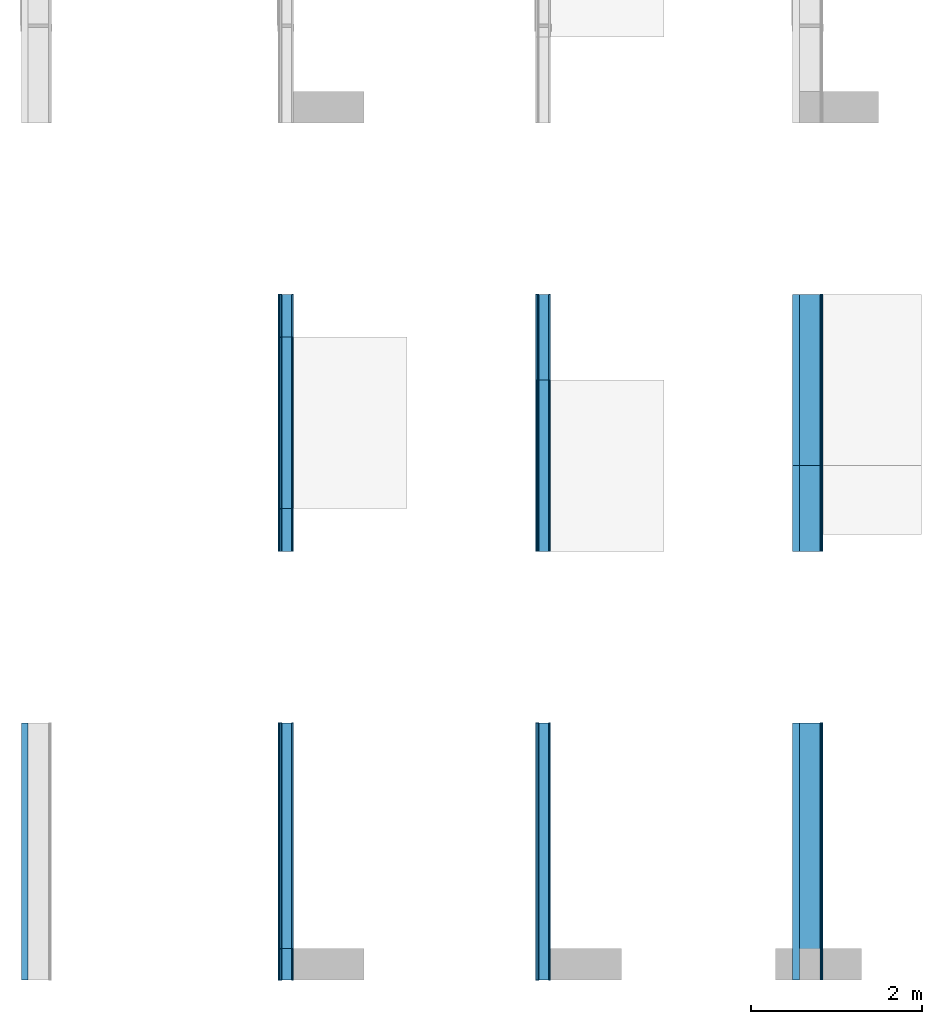
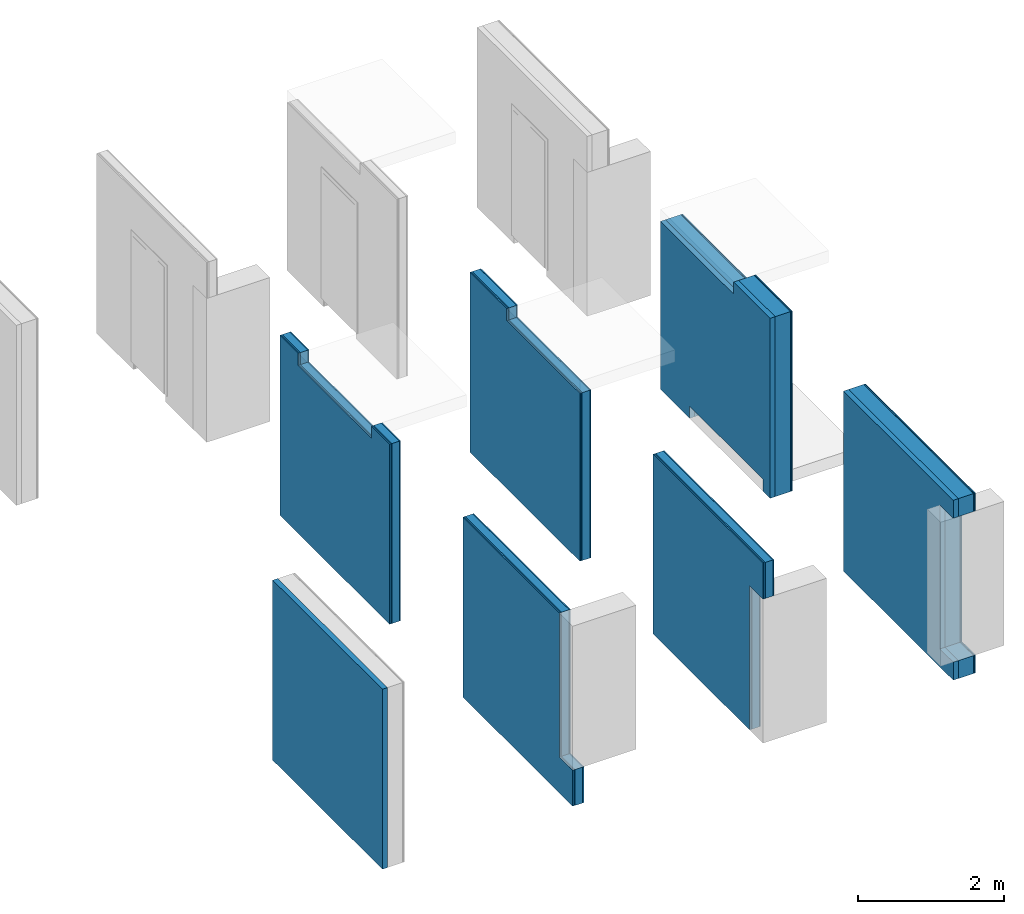
# One storey, part 2 of 2: 25 building element parts, 7 elements without a shape of their own.
"""IFC4 building model written with IfcOpenShell, lengths in metres."""

from ifc_helpers import new_model, entity, si_unit, converted_unit, derived_unit, direction, frame, origin_with_axes, place, context, subcontext, project, spatial, polygons, material, type_object, element, aggregate, save


model = new_model("IFC4")

# Units and contexts
model_context = context("Model", 3, precision=1e-05, world=origin_with_axes(), true_north=direction((0.0, 1.0)))
body_context = subcontext(model_context, "Body", "Model", "MODEL_VIEW")
ifc_project = project(units=[si_unit("LENGTHUNIT", "METRE"), si_unit("AREAUNIT", "SQUARE_METRE"), si_unit("VOLUMEUNIT", "CUBIC_METRE"), converted_unit("PLANEANGLEUNIT", "DEGREE", entity("IfcPlaneAngleMeasure", 0.0174532925199), si_unit("PLANEANGLEUNIT", "RADIAN"), dimensions=[0, 0, 0, 0, 0, 0, 0]), converted_unit("TIMEUNIT", "Year", entity("IfcTimeMeasure", 31556926.0), si_unit("TIMEUNIT", "SECOND"), dimensions=[0, 0, 1, 0, 0, 0, 0]), si_unit("MASSUNIT", "GRAM", prefix="KILO"), si_unit("THERMODYNAMICTEMPERATUREUNIT", "DEGREE_CELSIUS"), si_unit("LUMINOUSINTENSITYUNIT", "LUMEN"), si_unit("ENERGYUNIT", "JOULE", prefix="MEGA"), derived_unit("THERMALCONDUCTANCEUNIT", [(si_unit("POWERUNIT", "WATT"), 1), (si_unit("LENGTHUNIT", "METRE"), -1), (si_unit("THERMODYNAMICTEMPERATUREUNIT", "KELVIN"), -1)]), derived_unit("SPECIFICHEATCAPACITYUNIT", [(si_unit("ENERGYUNIT", "JOULE"), 1), (si_unit("MASSUNIT", "GRAM", prefix="KILO"), -1), (si_unit("THERMODYNAMICTEMPERATUREUNIT", "KELVIN"), -1)]), derived_unit("MASSDENSITYUNIT", [(si_unit("MASSUNIT", "GRAM", prefix="KILO"), 1), (si_unit("VOLUMEUNIT", "CUBIC_METRE"), -1)])], contexts=[model_context])

# Site, building, storey
site_placement = place(None, origin_with_axes())
site = spatial("IfcSite", under=ifc_project, at=site_placement, CompositionType="ELEMENT")
building_placement = place(site_placement, origin_with_axes())
building = spatial("IfcBuilding", under=site, at=building_placement, CompositionType="ELEMENT")
storey_placement = place(building_placement, origin_with_axes())
storey = spatial("IfcBuildingStorey", under=building, at=storey_placement, Name="EG", CompositionType="ELEMENT", Elevation=0.0)

# Wall, building element part
wall_type_1 = type_object("IfcWallType", PredefinedType="NOTDEFINED")
wall_1_placement = place(storey_placement, frame((0.0, 0.0, -0.15), z_axis=(0.0, 0.0, 1.0), x_axis=(0.0, -1.0, 0.0)))
wall_1 = element("IfcWall", 1, at=wall_1_placement, inside=storey, type_object=wall_type_1, Name="Wand-011", PredefinedType="NOTDEFINED")
ifc_material_1 = material(Name="Mineralwolle (1)-10")
building_element_part_1_placement = place(wall_1_placement, origin_with_axes())
building_element_part_1 = element("IfcBuildingElementPart", 2, at=building_element_part_1_placement, material=ifc_material_1, Name="Mineralwolle (1)-10", context=body_context, shape_type="Tessellation", body=[
    polygons([(3.0, 0.08, 0.0), (3.0, 0.0, 0.0), (0.0, 0.0, 0.0), (0.0, 0.08, 0.0), (3.0, 0.08, 3.0), (3.0, 0.0, 3.0), (0.0, 0.0, 3.0), (0.0, 0.08, 3.0)], [[[1, 2, 3, 4]], [[1, 5, 6, 2]], [[2, 6, 7, 3]], [[4, 3, 7, 8]], [[5, 1, 4, 8]], [[6, 5, 8, 7]]], closed=True),
])
aggregate(wall_1, [building_element_part_1])

# Wall, building element parts
wall_type_2 = type_object("IfcWallType", PredefinedType="NOTDEFINED")
wall_2_placement = place(storey_placement, frame((3.0, 0.0, -0.15), z_axis=(0.0, 0.0, 1.0), x_axis=(0.0, -1.0, 0.0)))
wall_2 = element("IfcWall", 3, at=wall_2_placement, inside=storey, type_object=wall_type_2, Name="Wand-011", PredefinedType="NOTDEFINED")
ifc_material_2 = material(Name="Gipskarton vertikal (1)-10 (2)")
building_element_part_2_placement = place(wall_2_placement, origin_with_axes())
building_element_part_2 = element("IfcBuildingElementPart", 4, at=building_element_part_2_placement, material=ifc_material_2, Name="Gipskarton vertikal (1)-10 (2)", context=body_context, shape_type="Tessellation", body=[
    polygons([(2.635, 0.156, 3.0), (2.635, 0.174, 3.0), (0.0, 0.174, 3.0), (0.0, 0.156, 3.0), (2.635, 0.174, 0.6), (2.635, 0.156, 0.6), (3.0, 0.174, 0.6), (3.0, 0.174, 0.0), (0.0, 0.174, 0.0), (0.0, 0.156, 0.0), (3.0, 0.156, 0.0), (3.0, 0.156, 0.6)], [[[1, 2, 3, 4]], [[5, 2, 1, 6]], [[5, 7, 8, 9, 3, 2]], [[4, 3, 9, 10]], [[6, 1, 4, 10, 11, 12]], [[7, 5, 6, 12]], [[7, 12, 11, 8]], [[9, 8, 11, 10]]], closed=True),
])
ifc_material_3 = material(Name="(2)-10")
building_element_part_3_placement = place(wall_2_placement, origin_with_axes())
building_element_part_3 = element("IfcBuildingElementPart", 5, at=building_element_part_3_placement, material=ifc_material_3, Name="(2)-10", context=body_context, shape_type="Tessellation", body=[
    polygons([(2.635, 0.036, 3.0), (2.635, 0.156, 3.0), (0.0, 0.156, 3.0), (0.0, 0.036, 3.0), (2.635, 0.156, 0.6), (2.635, 0.036, 0.6), (3.0, 0.156, 0.6), (3.0, 0.156, 0.0), (0.0, 0.156, 0.0), (0.0, 0.036, 0.0), (3.0, 0.036, 0.0), (3.0, 0.036, 0.6)], [[[1, 2, 3, 4]], [[5, 2, 1, 6]], [[5, 7, 8, 9, 3, 2]], [[4, 3, 9, 10]], [[6, 1, 4, 10, 11, 12]], [[7, 5, 6, 12]], [[7, 12, 11, 8]], [[9, 8, 11, 10]]], closed=True),
])
building_element_part_4_placement = place(wall_2_placement, origin_with_axes())
building_element_part_4 = element("IfcBuildingElementPart", 6, at=building_element_part_4_placement, material=ifc_material_2, Name="Gipskarton vertikal (1)-10 (2)", context=body_context, shape_type="Tessellation", body=[
    polygons([(2.635, 0.018, 3.0), (2.635, 0.036, 3.0), (0.0, 0.036, 3.0), (0.0, 0.018, 3.0), (2.635, 0.036, 0.6), (2.635, 0.018, 0.6), (3.0, 0.036, 0.6), (3.0, 0.036, 0.0), (0.0, 0.036, 0.0), (0.0, 0.018, 0.0), (3.0, 0.018, 0.0), (3.0, 0.018, 0.6)], [[[1, 2, 3, 4]], [[5, 2, 1, 6]], [[5, 7, 8, 9, 3, 2]], [[4, 3, 9, 10]], [[6, 1, 4, 10, 11, 12]], [[7, 5, 6, 12]], [[7, 12, 11, 8]], [[9, 8, 11, 10]]], closed=True),
])
building_element_part_5_placement = place(wall_2_placement, origin_with_axes())
building_element_part_5 = element("IfcBuildingElementPart", 7, at=building_element_part_5_placement, material=ifc_material_2, Name="Gipskarton vertikal (1)-10 (2)", context=body_context, shape_type="Tessellation", body=[
    polygons([(2.635, 0.0, 3.0), (2.635, 0.018, 3.0), (0.0, 0.018, 3.0), (0.0, 0.0, 3.0), (2.635, 0.018, 0.6), (2.635, 0.0, 0.6), (3.0, 0.018, 0.6), (3.0, 0.018, 0.0), (0.0, 0.018, 0.0), (0.0, 0.0, 0.0), (3.0, 0.0, 0.0), (3.0, 0.0, 0.6)], [[[1, 2, 3, 4]], [[5, 2, 1, 6]], [[5, 7, 8, 9, 3, 2]], [[4, 3, 9, 10]], [[6, 1, 4, 10, 11, 12]], [[7, 5, 6, 12]], [[7, 12, 11, 8]], [[9, 8, 11, 10]]], closed=True),
])
aggregate(wall_2, [building_element_part_2, building_element_part_3, building_element_part_4, building_element_part_5])

wall_3_placement = place(storey_placement, frame((6.0, 0.0, -0.15), z_axis=(0.0, 0.0, 1.0), x_axis=(0.0, -1.0, 0.0)))
wall_3 = element("IfcWall", 8, at=wall_3_placement, inside=storey, type_object=wall_type_2, Name="Wand-011", PredefinedType="NOTDEFINED")
building_element_part_6_placement = place(wall_3_placement, origin_with_axes())
building_element_part_6 = element("IfcBuildingElementPart", 9, at=building_element_part_6_placement, material=ifc_material_2, Name="Gipskarton vertikal (1)-10 (2)", context=body_context, shape_type="Tessellation", body=[
    polygons([(2.635, 0.174, 2.4), (2.635, 0.174, 0.0), (0.0, 0.174, 0.0), (0.0, 0.174, 3.0), (3.0, 0.174, 3.0), (3.0, 0.174, 2.4), (2.635, 0.156, 2.4), (2.635, 0.156, 0.0), (0.0, 0.156, 0.0), (0.0, 0.156, 3.0), (3.0, 0.156, 3.0), (3.0, 0.156, 2.4)], [[[1, 2, 3, 4, 5, 6]], [[2, 1, 7, 8]], [[2, 8, 9, 3]], [[10, 4, 3, 9]], [[10, 11, 5, 4]], [[12, 6, 5, 11]], [[1, 6, 12, 7]], [[7, 12, 11, 10, 9, 8]]], closed=True),
])
building_element_part_7_placement = place(wall_3_placement, origin_with_axes())
building_element_part_7 = element("IfcBuildingElementPart", 10, at=building_element_part_7_placement, material=ifc_material_3, Name="(2)-10", context=body_context, shape_type="Tessellation", body=[
    polygons([(2.635, 0.156, 2.4), (2.635, 0.156, 0.0), (0.0, 0.156, 0.0), (0.0, 0.156, 3.0), (3.0, 0.156, 3.0), (3.0, 0.156, 2.4), (2.635, 0.036, 2.4), (2.635, 0.036, 0.0), (0.0, 0.036, 0.0), (0.0, 0.036, 3.0), (3.0, 0.036, 3.0), (3.0, 0.036, 2.4)], [[[1, 2, 3, 4, 5, 6]], [[2, 1, 7, 8]], [[2, 8, 9, 3]], [[10, 4, 3, 9]], [[10, 11, 5, 4]], [[12, 6, 5, 11]], [[1, 6, 12, 7]], [[7, 12, 11, 10, 9, 8]]], closed=True),
])
building_element_part_8_placement = place(wall_3_placement, origin_with_axes())
building_element_part_8 = element("IfcBuildingElementPart", 11, at=building_element_part_8_placement, material=ifc_material_2, Name="Gipskarton vertikal (1)-10 (2)", context=body_context, shape_type="Tessellation", body=[
    polygons([(2.635, 0.036, 2.4), (2.635, 0.036, 0.0), (0.0, 0.036, 0.0), (0.0, 0.036, 3.0), (3.0, 0.036, 3.0), (3.0, 0.036, 2.4), (2.635, 0.018, 2.4), (2.635, 0.018, 0.0), (0.0, 0.018, 0.0), (0.0, 0.018, 3.0), (3.0, 0.018, 3.0), (3.0, 0.018, 2.4)], [[[1, 2, 3, 4, 5, 6]], [[2, 1, 7, 8]], [[2, 8, 9, 3]], [[10, 4, 3, 9]], [[10, 11, 5, 4]], [[12, 6, 5, 11]], [[1, 6, 12, 7]], [[7, 12, 11, 10, 9, 8]]], closed=True),
])
building_element_part_9_placement = place(wall_3_placement, origin_with_axes())
building_element_part_9 = element("IfcBuildingElementPart", 12, at=building_element_part_9_placement, material=ifc_material_2, Name="Gipskarton vertikal (1)-10 (2)", context=body_context, shape_type="Tessellation", body=[
    polygons([(2.635, 0.018, 2.4), (2.635, 0.018, 0.0), (0.0, 0.018, 0.0), (0.0, 0.018, 3.0), (3.0, 0.018, 3.0), (3.0, 0.018, 2.4), (2.635, 0.0, 2.4), (2.635, 0.0, 0.0), (0.0, 0.0, 0.0), (0.0, 0.0, 3.0), (3.0, 0.0, 3.0), (3.0, 0.0, 2.4)], [[[1, 2, 3, 4, 5, 6]], [[2, 1, 7, 8]], [[2, 8, 9, 3]], [[10, 4, 3, 9]], [[10, 11, 5, 4]], [[12, 6, 5, 11]], [[1, 6, 12, 7]], [[7, 12, 11, 10, 9, 8]]], closed=True),
])
aggregate(wall_3, [building_element_part_6, building_element_part_7, building_element_part_8, building_element_part_9])

wall_4_placement = place(storey_placement, frame((9.0, 0.0, -0.15), z_axis=(0.0, 0.0, 1.0), x_axis=(0.0, -1.0, 0.0)))
wall_4 = element("IfcWall", 13, at=wall_4_placement, inside=storey, type_object=wall_type_1, Name="Wand-011", PredefinedType="NOTDEFINED")
ifc_material_4 = material(Name="Gipskarton vertikal (1)-10")
building_element_part_10_placement = place(wall_4_placement, origin_with_axes())
building_element_part_10 = element("IfcBuildingElementPart", 14, at=building_element_part_10_placement, material=ifc_material_4, Name="Gipskarton vertikal (1)-10", context=body_context, shape_type="Tessellation", body=[
    polygons([(2.635, 0.35, 0.3), (3.0, 0.35, 0.3), (3.0, 0.35, 0.0), (0.0, 0.35, 0.0), (0.0, 0.35, 3.0), (3.0, 0.35, 3.00000000224), (3.0, 0.35, 2.7), (2.635, 0.35, 2.7), (2.635, 0.335000002235, 0.3), (3.0, 0.335000002235, 0.3), (3.0, 0.335000002235, 0.0), (0.0, 0.335, 0.0), (0.0, 0.335, 3.0), (3.0, 0.335000002235, 3.00000000224), (3.0, 0.335000002235, 2.7), (2.635, 0.335000002235, 2.7)], [[[1, 2, 3, 4, 5, 6, 7, 8]], [[2, 1, 9, 10]], [[2, 10, 11, 3]], [[4, 3, 11, 12]], [[13, 5, 4, 12]], [[13, 14, 6, 5]], [[15, 7, 6, 14]], [[8, 7, 15, 16]], [[1, 8, 16, 9]], [[16, 15, 14, 13, 12, 11, 10, 9]]], closed=True),
])
ifc_material_5 = material(Name="OSB (1)-10")
building_element_part_11_placement = place(wall_4_placement, origin_with_axes())
building_element_part_11 = element("IfcBuildingElementPart", 15, at=building_element_part_11_placement, material=ifc_material_5, Name="OSB (1)-10", context=body_context, shape_type="Tessellation", body=[
    polygons([(2.635, 0.335000002235, 0.3), (3.0, 0.335000002235, 0.3), (3.0, 0.335000002235, 0.0), (0.0, 0.335, 0.0), (0.0, 0.335, 3.0), (3.0, 0.335000002235, 3.00000000224), (3.0, 0.335000002235, 2.7), (2.635, 0.335000002235, 2.7), (2.635, 0.319999999255, 0.3), (3.0, 0.319999999255, 0.3), (3.0, 0.319999999255, 0.0), (0.0, 0.32, 0.0), (0.0, 0.32, 3.0), (3.0, 0.319999999255, 3.00000000224), (3.0, 0.319999999255, 2.7), (2.635, 0.319999999255, 2.7)], [[[1, 2, 3, 4, 5, 6, 7, 8]], [[2, 1, 9, 10]], [[2, 10, 11, 3]], [[4, 3, 11, 12]], [[13, 5, 4, 12]], [[13, 14, 6, 5]], [[15, 7, 6, 14]], [[8, 7, 15, 16]], [[1, 8, 16, 9]], [[16, 15, 14, 13, 12, 11, 10, 9]]], closed=True),
])
ifc_material_6 = material(Name="(1)-10")
building_element_part_12_placement = place(wall_4_placement, origin_with_axes())
building_element_part_12 = element("IfcBuildingElementPart", 16, at=building_element_part_12_placement, material=ifc_material_6, Name="(1)-10", context=body_context, shape_type="Tessellation", body=[
    polygons([(2.635, 0.319999999255, 0.3), (3.0, 0.319999999255, 0.3), (3.0, 0.319999999255, 0.0), (0.0, 0.32, 0.0), (0.0, 0.32, 3.0), (3.0, 0.319999999255, 3.00000000224), (3.0, 0.319999999255, 2.7), (2.635, 0.319999999255, 2.7), (2.635, 0.0799999985099, 0.3), (3.0, 0.0799999985099, 0.3), (3.0, 0.0799999985099, 0.0), (0.0, 0.08, 0.0), (0.0, 0.08, 3.0), (3.0, 0.0799999985099, 3.00000000224), (3.0, 0.0799999985099, 2.7), (2.635, 0.0799999985099, 2.7)], [[[1, 2, 3, 4, 5, 6, 7, 8]], [[2, 1, 9, 10]], [[2, 10, 11, 3]], [[4, 3, 11, 12]], [[13, 5, 4, 12]], [[13, 14, 6, 5]], [[15, 7, 6, 14]], [[8, 7, 15, 16]], [[1, 8, 16, 9]], [[16, 15, 14, 13, 12, 11, 10, 9]]], closed=True),
])
building_element_part_13_placement = place(wall_4_placement, origin_with_axes())
building_element_part_13 = element("IfcBuildingElementPart", 17, at=building_element_part_13_placement, material=ifc_material_1, Name="Mineralwolle (1)-10", context=body_context, shape_type="Tessellation", body=[
    polygons([(2.635, 0.0799999985099, 0.3), (3.0, 0.0799999985099, 0.3), (3.0, 0.0799999985099, 0.0), (0.0, 0.08, 0.0), (0.0, 0.08, 3.0), (3.0, 0.0799999985099, 3.00000000224), (3.0, 0.0799999985099, 2.7), (2.635, 0.0799999985099, 2.7), (2.635, 0.0, 0.3), (3.0, 0.0, 0.3), (3.0, 0.0, 0.0), (0.0, 0.0, 0.0), (0.0, 0.0, 3.0), (3.0, 0.0, 3.00000000224), (3.0, 0.0, 2.7), (2.635, 0.0, 2.7)], [[[1, 2, 3, 4, 5, 6, 7, 8]], [[2, 1, 9, 10]], [[2, 10, 11, 3]], [[4, 3, 11, 12]], [[13, 5, 4, 12]], [[13, 14, 6, 5]], [[15, 7, 6, 14]], [[8, 7, 15, 16]], [[1, 8, 16, 9]], [[16, 15, 14, 13, 12, 11, 10, 9]]], closed=True),
])
aggregate(wall_4, [building_element_part_10, building_element_part_11, building_element_part_12, building_element_part_13])

wall_5_placement = place(storey_placement, frame((9.0, 5.0, -0.15), z_axis=(0.0, 0.0, 1.0), x_axis=(0.0, -1.0, 0.0)))
wall_5 = element("IfcWall", 18, at=wall_5_placement, inside=storey, type_object=wall_type_1, Name="Wand-011", PredefinedType="NOTDEFINED")
building_element_part_14_placement = place(wall_5_placement, origin_with_axes())
building_element_part_14 = element("IfcBuildingElementPart", 19, at=building_element_part_14_placement, material=ifc_material_4, Name="Gipskarton vertikal (1)-10", context=body_context, shape_type="Tessellation", body=[
    polygons([(2.8, 0.35, 0.0), (2.8, 0.35, 0.2), (0.8, 0.35, 0.2), (0.8, 0.35, 0.0), (0.0, 0.35, 0.0), (0.0, 0.35, 2.8), (2.0, 0.35, 2.8), (2.0, 0.35, 3.0), (3.0, 0.35, 3.0), (3.0, 0.35, 0.0), (2.8, 0.335, 0.0), (2.8, 0.335, 0.2), (0.8, 0.335, 0.2), (0.8, 0.335, 0.0), (0.0, 0.335, 0.0), (0.0, 0.335, 2.8), (2.0, 0.335, 2.8), (2.0, 0.335, 3.0), (3.0, 0.335, 3.0), (3.0, 0.335, 0.0)], [[[1, 2, 3, 4, 5, 6, 7, 8, 9, 10]], [[2, 1, 11, 12]], [[3, 2, 12, 13]], [[4, 3, 13, 14]], [[4, 14, 15, 5]], [[16, 6, 5, 15]], [[7, 6, 16, 17]], [[18, 8, 7, 17]], [[8, 18, 19, 9]], [[20, 10, 9, 19]], [[11, 1, 10, 20]], [[12, 11, 20, 19, 18, 17, 16, 15, 14, 13]]], closed=True),
])
building_element_part_15_placement = place(wall_5_placement, origin_with_axes())
building_element_part_15 = element("IfcBuildingElementPart", 20, at=building_element_part_15_placement, material=ifc_material_5, Name="OSB (1)-10", context=body_context, shape_type="Tessellation", body=[
    polygons([(2.8, 0.335, 0.0), (2.8, 0.335, 0.2), (0.8, 0.335, 0.2), (0.8, 0.335, 0.0), (0.0, 0.335, 0.0), (0.0, 0.335, 2.8), (2.0, 0.335, 2.8), (2.0, 0.335, 3.0), (3.0, 0.335, 3.0), (3.0, 0.335, 0.0), (2.8, 0.32, 0.0), (2.8, 0.32, 0.2), (0.8, 0.32, 0.2), (0.8, 0.32, 0.0), (0.0, 0.32, 0.0), (0.0, 0.32, 2.8), (2.0, 0.32, 2.8), (2.0, 0.32, 3.0), (3.0, 0.32, 3.0), (3.0, 0.32, 0.0)], [[[1, 2, 3, 4, 5, 6, 7, 8, 9, 10]], [[2, 1, 11, 12]], [[3, 2, 12, 13]], [[4, 3, 13, 14]], [[4, 14, 15, 5]], [[16, 6, 5, 15]], [[7, 6, 16, 17]], [[18, 8, 7, 17]], [[8, 18, 19, 9]], [[20, 10, 9, 19]], [[11, 1, 10, 20]], [[12, 11, 20, 19, 18, 17, 16, 15, 14, 13]]], closed=True),
])
building_element_part_16_placement = place(wall_5_placement, origin_with_axes())
building_element_part_16 = element("IfcBuildingElementPart", 21, at=building_element_part_16_placement, material=ifc_material_6, Name="(1)-10", context=body_context, shape_type="Tessellation", body=[
    polygons([(2.8, 0.32, 0.0), (2.8, 0.32, 0.2), (0.8, 0.32, 0.2), (0.8, 0.32, 0.0), (0.0, 0.32, 0.0), (0.0, 0.32, 2.8), (2.0, 0.32, 2.8), (2.0, 0.32, 3.0), (3.0, 0.32, 3.0), (3.0, 0.32, 0.0), (2.8, 0.08, 0.0), (2.8, 0.08, 0.2), (0.8, 0.08, 0.2), (0.8, 0.08, 0.0), (0.0, 0.08, 0.0), (0.0, 0.08, 2.8), (2.0, 0.08, 2.8), (2.0, 0.08, 3.0), (3.0, 0.08, 3.0), (3.0, 0.08, 0.0)], [[[1, 2, 3, 4, 5, 6, 7, 8, 9, 10]], [[2, 1, 11, 12]], [[3, 2, 12, 13]], [[4, 3, 13, 14]], [[4, 14, 15, 5]], [[16, 6, 5, 15]], [[7, 6, 16, 17]], [[18, 8, 7, 17]], [[8, 18, 19, 9]], [[20, 10, 9, 19]], [[11, 1, 10, 20]], [[12, 11, 20, 19, 18, 17, 16, 15, 14, 13]]], closed=True),
])
building_element_part_17_placement = place(wall_5_placement, origin_with_axes())
building_element_part_17 = element("IfcBuildingElementPart", 22, at=building_element_part_17_placement, material=ifc_material_1, Name="Mineralwolle (1)-10", context=body_context, shape_type="Tessellation", body=[
    polygons([(2.8, 0.08, 0.0), (2.8, 0.08, 0.2), (0.8, 0.08, 0.2), (0.8, 0.08, 0.0), (0.0, 0.08, 0.0), (0.0, 0.08, 2.8), (2.0, 0.08, 2.8), (2.0, 0.08, 3.0), (3.0, 0.08, 3.0), (3.0, 0.08, 0.0), (2.8, 0.0, 0.0), (2.8, 0.0, 0.2), (0.8, 0.0, 0.2), (0.8, 0.0, 0.0), (0.0, 0.0, 0.0), (0.0, 0.0, 2.8), (2.0, 0.0, 2.8), (2.0, 0.0, 3.0), (3.0, 0.0, 3.0), (3.0, 0.0, 0.0)], [[[1, 2, 3, 4, 5, 6, 7, 8, 9, 10]], [[2, 1, 11, 12]], [[3, 2, 12, 13]], [[4, 3, 13, 14]], [[4, 14, 15, 5]], [[16, 6, 5, 15]], [[7, 6, 16, 17]], [[18, 8, 7, 17]], [[8, 18, 19, 9]], [[20, 10, 9, 19]], [[11, 1, 10, 20]], [[12, 11, 20, 19, 18, 17, 16, 15, 14, 13]]], closed=True),
])
aggregate(wall_5, [building_element_part_14, building_element_part_15, building_element_part_16, building_element_part_17])

wall_6_placement = place(storey_placement, frame((3.0, 5.0, -0.15), z_axis=(0.0, 0.0, 1.0), x_axis=(0.0, -1.0, 0.0)))
wall_6 = element("IfcWall", 23, at=wall_6_placement, inside=storey, type_object=wall_type_2, Name="Wand-011", PredefinedType="NOTDEFINED")
building_element_part_18_placement = place(wall_6_placement, origin_with_axes())
building_element_part_18 = element("IfcBuildingElementPart", 24, at=building_element_part_18_placement, material=ifc_material_2, Name="Gipskarton vertikal (1)-10 (2)", context=body_context, shape_type="Tessellation", body=[
    polygons([(0.5, 0.156, 3.0), (0.5, 0.174, 3.0), (0.0, 0.174, 3.0), (0.0, 0.156, 3.0), (0.5, 0.174, 2.8), (0.5, 0.156, 2.8), (2.5, 0.174, 2.8), (2.5, 0.174, 3.0), (3.0, 0.174, 3.0), (3.0, 0.174, 0.0), (0.0, 0.174, 0.0), (0.0, 0.156, 0.0), (3.0, 0.156, 0.0), (3.0, 0.156, 3.0), (2.5, 0.156, 3.0), (2.5, 0.156, 2.8)], [[[1, 2, 3, 4]], [[5, 2, 1, 6]], [[7, 8, 9, 10, 11, 3, 2, 5]], [[3, 11, 12, 4]], [[6, 1, 4, 12, 13, 14, 15, 16]], [[7, 5, 6, 16]], [[15, 8, 7, 16]], [[8, 15, 14, 9]], [[13, 10, 9, 14]], [[11, 10, 13, 12]]], closed=True),
])
building_element_part_19_placement = place(wall_6_placement, origin_with_axes())
building_element_part_19 = element("IfcBuildingElementPart", 25, at=building_element_part_19_placement, material=ifc_material_3, Name="(2)-10", context=body_context, shape_type="Tessellation", body=[
    polygons([(0.5, 0.036, 3.0), (0.5, 0.156, 3.0), (0.0, 0.156, 3.0), (0.0, 0.036, 3.0), (0.5, 0.156, 2.8), (0.5, 0.036, 2.8), (2.5, 0.156, 2.8), (2.5, 0.156, 3.0), (3.0, 0.156, 3.0), (3.0, 0.156, 0.0), (0.0, 0.156, 0.0), (0.0, 0.036, 0.0), (3.0, 0.036, 0.0), (3.0, 0.036, 3.0), (2.5, 0.036, 3.0), (2.5, 0.036, 2.8)], [[[1, 2, 3, 4]], [[5, 2, 1, 6]], [[7, 8, 9, 10, 11, 3, 2, 5]], [[3, 11, 12, 4]], [[6, 1, 4, 12, 13, 14, 15, 16]], [[7, 5, 6, 16]], [[15, 8, 7, 16]], [[8, 15, 14, 9]], [[13, 10, 9, 14]], [[11, 10, 13, 12]]], closed=True),
])
building_element_part_20_placement = place(wall_6_placement, origin_with_axes())
building_element_part_20 = element("IfcBuildingElementPart", 26, at=building_element_part_20_placement, material=ifc_material_2, Name="Gipskarton vertikal (1)-10 (2)", context=body_context, shape_type="Tessellation", body=[
    polygons([(0.5, 0.018, 3.0), (0.5, 0.036, 3.0), (0.0, 0.036, 3.0), (0.0, 0.018, 3.0), (0.5, 0.036, 2.8), (0.5, 0.018, 2.8), (2.5, 0.036, 2.8), (2.5, 0.036, 3.0), (3.0, 0.036, 3.0), (3.0, 0.036, 0.0), (0.0, 0.036, 0.0), (0.0, 0.018, 0.0), (3.0, 0.018, 0.0), (3.0, 0.018, 3.0), (2.5, 0.018, 3.0), (2.5, 0.018, 2.8)], [[[1, 2, 3, 4]], [[5, 2, 1, 6]], [[7, 8, 9, 10, 11, 3, 2, 5]], [[3, 11, 12, 4]], [[6, 1, 4, 12, 13, 14, 15, 16]], [[7, 5, 6, 16]], [[15, 8, 7, 16]], [[8, 15, 14, 9]], [[13, 10, 9, 14]], [[11, 10, 13, 12]]], closed=True),
])
building_element_part_21_placement = place(wall_6_placement, origin_with_axes())
building_element_part_21 = element("IfcBuildingElementPart", 27, at=building_element_part_21_placement, material=ifc_material_2, Name="Gipskarton vertikal (1)-10 (2)", context=body_context, shape_type="Tessellation", body=[
    polygons([(0.5, 0.0, 3.0), (0.5, 0.018, 3.0), (0.0, 0.018, 3.0), (0.0, 0.0, 3.0), (0.5, 0.018, 2.8), (0.5, 0.0, 2.8), (2.5, 0.018, 2.8), (2.5, 0.018, 3.0), (3.0, 0.018, 3.0), (3.0, 0.018, 0.0), (0.0, 0.018, 0.0), (0.0, 0.0, 0.0), (3.0, 0.0, 0.0), (3.0, 0.0, 3.0), (2.5, 0.0, 3.0), (2.5, 0.0, 2.8)], [[[1, 2, 3, 4]], [[5, 2, 1, 6]], [[7, 8, 9, 10, 11, 3, 2, 5]], [[3, 11, 12, 4]], [[6, 1, 4, 12, 13, 14, 15, 16]], [[7, 5, 6, 16]], [[15, 8, 7, 16]], [[8, 15, 14, 9]], [[13, 10, 9, 14]], [[11, 10, 13, 12]]], closed=True),
])
aggregate(wall_6, [building_element_part_18, building_element_part_19, building_element_part_20, building_element_part_21])

wall_7_placement = place(storey_placement, frame((6.0, 5.0, -0.15), z_axis=(0.0, 0.0, 1.0), x_axis=(0.0, -1.0, 0.0)))
wall_7 = element("IfcWall", 28, at=wall_7_placement, inside=storey, type_object=wall_type_2, Name="Wand-011", PredefinedType="NOTDEFINED")
building_element_part_22_placement = place(wall_7_placement, origin_with_axes())
building_element_part_22 = element("IfcBuildingElementPart", 29, at=building_element_part_22_placement, material=ifc_material_2, Name="Gipskarton vertikal (1)-10 (2)", context=body_context, shape_type="Tessellation", body=[
    polygons([(1.0, 0.156, 3.0), (1.0, 0.174, 3.0), (0.0, 0.174, 3.0), (0.0, 0.156, 3.0), (1.0, 0.174, 2.8), (1.0, 0.156, 2.8), (3.0, 0.174, 2.8), (3.0, 0.174, 0.0), (0.0, 0.174, 0.0), (0.0, 0.156, 0.0), (3.0, 0.156, 0.0), (3.0, 0.156, 2.8)], [[[1, 2, 3, 4]], [[5, 2, 1, 6]], [[5, 7, 8, 9, 3, 2]], [[3, 9, 10, 4]], [[6, 1, 4, 10, 11, 12]], [[7, 5, 6, 12]], [[7, 12, 11, 8]], [[9, 8, 11, 10]]], closed=True),
])
building_element_part_23_placement = place(wall_7_placement, origin_with_axes())
building_element_part_23 = element("IfcBuildingElementPart", 30, at=building_element_part_23_placement, material=ifc_material_3, Name="(2)-10", context=body_context, shape_type="Tessellation", body=[
    polygons([(1.0, 0.036, 3.0), (1.0, 0.156, 3.0), (0.0, 0.156, 3.0), (0.0, 0.036, 3.0), (1.0, 0.156, 2.8), (1.0, 0.036, 2.8), (3.0, 0.156, 2.8), (3.0, 0.156, 0.0), (0.0, 0.156, 0.0), (0.0, 0.036, 0.0), (3.0, 0.036, 0.0), (3.0, 0.036, 2.8)], [[[1, 2, 3, 4]], [[5, 2, 1, 6]], [[5, 7, 8, 9, 3, 2]], [[3, 9, 10, 4]], [[6, 1, 4, 10, 11, 12]], [[7, 5, 6, 12]], [[7, 12, 11, 8]], [[9, 8, 11, 10]]], closed=True),
])
building_element_part_24_placement = place(wall_7_placement, origin_with_axes())
building_element_part_24 = element("IfcBuildingElementPart", 31, at=building_element_part_24_placement, material=ifc_material_2, Name="Gipskarton vertikal (1)-10 (2)", context=body_context, shape_type="Tessellation", body=[
    polygons([(1.0, 0.018, 3.0), (1.0, 0.036, 3.0), (0.0, 0.036, 3.0), (0.0, 0.018, 3.0), (1.0, 0.036, 2.8), (1.0, 0.018, 2.8), (3.0, 0.036, 2.8), (3.0, 0.036, 0.0), (0.0, 0.036, 0.0), (0.0, 0.018, 0.0), (3.0, 0.018, 0.0), (3.0, 0.018, 2.8)], [[[1, 2, 3, 4]], [[5, 2, 1, 6]], [[5, 7, 8, 9, 3, 2]], [[3, 9, 10, 4]], [[6, 1, 4, 10, 11, 12]], [[7, 5, 6, 12]], [[7, 12, 11, 8]], [[9, 8, 11, 10]]], closed=True),
])
building_element_part_25_placement = place(wall_7_placement, origin_with_axes())
building_element_part_25 = element("IfcBuildingElementPart", 32, at=building_element_part_25_placement, material=ifc_material_2, Name="Gipskarton vertikal (1)-10 (2)", context=body_context, shape_type="Tessellation", body=[
    polygons([(1.0, 0.0, 3.0), (1.0, 0.018, 3.0), (0.0, 0.018, 3.0), (0.0, 0.0, 3.0), (1.0, 0.018, 2.8), (1.0, 0.0, 2.8), (3.0, 0.018, 2.8), (3.0, 0.018, 0.0), (0.0, 0.018, 0.0), (0.0, 0.0, 0.0), (3.0, 0.0, 0.0), (3.0, 0.0, 2.8)], [[[1, 2, 3, 4]], [[5, 2, 1, 6]], [[5, 7, 8, 9, 3, 2]], [[3, 9, 10, 4]], [[6, 1, 4, 10, 11, 12]], [[7, 5, 6, 12]], [[7, 12, 11, 8]], [[9, 8, 11, 10]]], closed=True),
])
aggregate(wall_7, [building_element_part_22, building_element_part_23, building_element_part_24, building_element_part_25])

save(model, "model.ifc")
